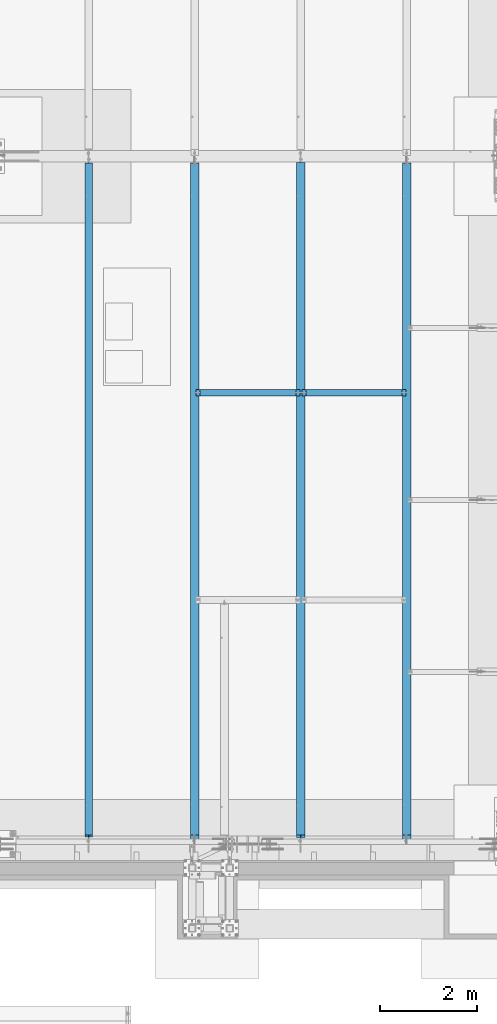
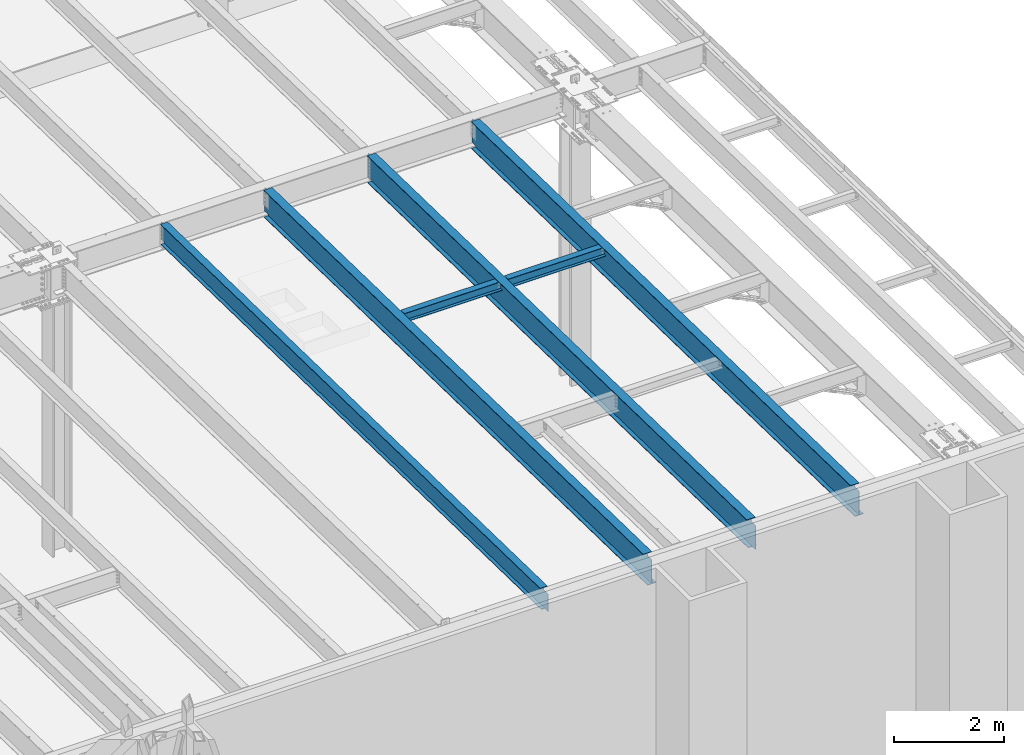
# One storey, part 1112 of 1763: 6 beams, 6 elements without a shape of their own.
"""IFC2X3 building model written with IfcOpenShell, lengths in millimetres."""

from ifc_helpers import new_model, si_unit, frame, origin_with_axes, place, context, subcontext, project, spatial, faceted_brep, material, type_object, element, aggregate, save


model = new_model("IFC2X3")

# Units and contexts
model_context = context("Model", 3, precision=1e-05, world=origin_with_axes())
body_context = subcontext(model_context, "Body", "Model", "MODEL_VIEW")
ifc_project = project(units=[si_unit("LENGTHUNIT", "METRE", prefix="MILLI"), si_unit("AREAUNIT", "SQUARE_METRE"), si_unit("VOLUMEUNIT", "CUBIC_METRE"), si_unit("MASSUNIT", "GRAM", prefix="KILO"), si_unit("TIMEUNIT", "SECOND"), si_unit("PLANEANGLEUNIT", "RADIAN"), si_unit("SOLIDANGLEUNIT", "STERADIAN"), si_unit("THERMODYNAMICTEMPERATUREUNIT", "DEGREE_CELSIUS"), si_unit("LUMINOUSINTENSITYUNIT", "LUMEN")], contexts=[model_context])

# Site, building, storey
site_placement = place(None, origin_with_axes())
site = spatial("IfcSite", under=ifc_project, at=site_placement, CompositionType="ELEMENT")
building_placement = place(site_placement, origin_with_axes())
building = spatial("IfcBuilding", under=site, at=building_placement, Name="Undefined", CompositionType="ELEMENT")
storey_placement = place(building_placement, origin_with_axes())
storey = spatial("IfcBuildingStorey", under=building, at=storey_placement, Name="Undefined", CompositionType="ELEMENT", Elevation=0.0)

# Assembly, beam
assembly_1_placement = place(storey_placement, origin_with_axes())
assembly_1 = element("IfcElementAssembly", 1, at=assembly_1_placement, inside=storey, Name="BEAM", AssemblyPlace="NOTDEFINED", PredefinedType="RIGID_FRAME")
ifc_material = material(Name="STEEL/A992")
beam_type_1 = type_object("IfcBeamType", Name="W8X18", PredefinedType="NOTDEFINED")
beam_1_placement = place(assembly_1_placement, frame((-30581.0372736983, -4419.6, 11907.1626782421), z_axis=(0.0, 0.0, 1.0), x_axis=(1.0, 0.0, 0.0)))
beam_1 = element("IfcBeam", 2, at=beam_1_placement, type_object=beam_type_1, material=ifc_material, Name="BEAM", ObjectType="W8X18", context=body_context, shape_type="Brep", body=[
    faceted_brep([(87.3125001907247, -3.17500000000018, 64.8275016680727), (87.3125001907247, 3.17500000000018, 64.8275016680727), (17.4624999999905, 3.17500000000018, 64.8275016680727), (17.4624999999905, -3.17500000000018, 64.8275016680727), (92.1725797087711, -3.17500000000018, 65.7942315906603), (92.1725797087711, 3.17500000000018, 65.7942315906603), (96.2927561769247, -3.17500000000018, 68.5472454911378), (96.2927561769247, 3.17500000000018, 68.5472454911378), (97.1527139098253, -3.17500000000018, 69.8342631898486), (97.1527139098253, 3.17500000000018, 69.8342631898486), (17.4624999999905, -3.17500000000018, -95.25), (17.4624999999905, -66.6750000000002, -95.25), (2166.93749999999, -66.6750000000002, -95.25), (2166.93749999999, -3.17500000000018, -95.25), (17.4624999999905, -66.6750000000002, -103.1875), (2166.93749999999, -66.6750000000002, -103.1875), (17.4624999999905, 66.6750000000002, -103.1875), (2166.93749999999, 66.6750000000002, -103.1875), (17.4624999999905, 66.6750000000002, -95.25), (2166.93749999999, 66.6750000000002, -95.25), (17.4624999999905, 3.17500000000018, -95.25), (2166.93749999999, 3.17500000000018, -95.25), (2166.93749999999, 3.17500000000018, 64.8275016741882), (2166.93749999999, -3.17500000000018, 64.8275016741882), (2097.08749980926, 3.17500000000018, 64.8275016741882), (2097.08749980926, -3.17500000000018, 64.8275016741882), (2092.22742029121, 3.17500000000018, 65.7942315967757), (2092.22742029121, -3.17500000000018, 65.7942315967757), (2088.10724382306, 3.17500000000018, 68.5472454972532), (2088.10724382306, -3.17500000000018, 68.5472454972532), (2087.2472860971, 3.17500000000018, 69.8342631855776), (2087.2472860971, -3.17500000000018, 69.8342631855776), (2086.51974687482, 3.17500000000018, 70.3203893521513), (2086.51974687482, -3.17500000000018, 70.3203893521513), (2083.76673297434, 3.17500000000018, 74.440565820305), (2083.76673297434, -3.17500000000018, 74.440565820305), (2082.80000305175, 3.17500000000018, 79.3006453383514), (2082.80000305175, -3.17500000000018, 79.3006453383514), (2082.80000305175, -66.6750000000002, 103.1875), (2082.80000305175, -66.6750000000002, 95.25), (2082.80000305175, -3.17500000000018, 95.25), (2082.80000305175, 3.17500000000018, 95.25), (2082.80000305175, 66.6750000000002, 95.25), (2082.80000305175, 66.6750000000002, 103.1875), (101.599996948244, 3.17500000000018, 95.25), (101.599996948244, 66.6750000000002, 95.25), (101.599996948244, 66.6750000000002, 103.1875), (101.599996948244, -66.6750000000002, 103.1875), (101.599996948244, -66.6750000000002, 95.25), (101.599996948244, -3.17500000000018, 95.25), (101.599996948244, 3.17500000000018, 79.3006453379949), (101.599996948244, -3.17500000000018, 79.3006453379949), (100.633267025656, 3.17500000000018, 74.4405658199485), (100.633267025656, -3.17500000000018, 74.4405658199485), (97.8802531251786, 3.17500000000018, 70.3203893517948), (97.8802531251786, -3.17500000000018, 70.3203893517948)], [[[0, 1, 2, 3]], [[4, 5, 1, 0]], [[6, 7, 5, 4]], [[8, 9, 7, 6]], [[10, 11, 12, 13]], [[11, 14, 15, 12]], [[14, 16, 17, 15]], [[16, 18, 19, 17]], [[18, 20, 21, 19]], [[13, 12, 15, 17, 19, 21, 22, 23]], [[23, 22, 24, 25]], [[25, 24, 26, 27]], [[27, 26, 28, 29]], [[29, 28, 30, 31]], [[32, 33, 31, 30]], [[33, 32, 34, 35]], [[35, 34, 36, 37]], [[38, 39, 40, 37, 36, 41, 42, 43]], [[42, 41, 44, 45]], [[43, 42, 45, 46]], [[38, 43, 46, 47]], [[39, 38, 47, 48]], [[40, 39, 48, 49]], [[47, 46, 45, 44, 50, 51, 49, 48]], [[51, 50, 52, 53]], [[53, 52, 54, 55]], [[4, 0, 3, 10, 13, 23, 25, 27, 29, 31, 33, 35, 37, 40, 49, 51, 53, 55, 8, 6]], [[20, 18, 16, 14, 11, 10, 3, 2]], [[54, 52, 50, 44, 41, 36, 34, 32, 30, 28, 26, 24, 22, 21, 20, 2, 1, 5, 7, 9]], [[55, 54, 9, 8]]]),
])
aggregate(assembly_1, [beam_1])

assembly_2_placement = place(storey_placement, origin_with_axes())
assembly_2 = element("IfcElementAssembly", 3, at=assembly_2_placement, inside=storey, Name="BEAM", AssemblyPlace="NOTDEFINED", PredefinedType="RIGID_FRAME")
beam_2_placement = place(assembly_2_placement, frame((-28396.6372736983, -4419.6, 11907.1626782421), z_axis=(0.0, 0.0, 1.0), x_axis=(1.0, 0.0, 0.0)))
beam_2 = element("IfcBeam", 4, at=beam_2_placement, type_object=beam_type_1, material=ifc_material, Name="BEAM", ObjectType="W8X18", context=body_context, shape_type="Brep", body=[
    faceted_brep([(87.3125001907247, -3.17500000000018, 64.8275016680727), (87.3125001907247, 3.17500000000018, 64.8275016680727), (17.4624999999905, 3.17500000000018, 64.8275016680727), (17.4624999999905, -3.17500000000018, 64.8275016680727), (92.1725797087711, -3.17500000000018, 65.7942315906603), (92.1725797087711, 3.17500000000018, 65.7942315906603), (96.2927561769247, -3.17500000000018, 68.5472454911378), (96.2927561769247, 3.17500000000018, 68.5472454911378), (97.1527139098253, -3.17500000000018, 69.8342631898486), (97.1527139098253, 3.17500000000018, 69.8342631898486), (17.4624999999905, -3.17500000000018, -95.25), (17.4624999999905, -66.6750000000002, -95.25), (2166.93749999999, -66.6750000000002, -95.25), (2166.93749999999, -3.17500000000018, -95.25), (17.4624999999905, -66.6750000000002, -103.1875), (2166.93749999999, -66.6750000000002, -103.1875), (17.4624999999905, 66.6750000000002, -103.1875), (2166.93749999999, 66.6750000000002, -103.1875), (17.4624999999905, 66.6750000000002, -95.25), (2166.93749999999, 66.6750000000002, -95.25), (17.4624999999905, 3.17500000000018, -95.25), (2166.93749999999, 3.17500000000018, -95.25), (2166.93749999999, 3.17500000000018, 64.8275016741882), (2166.93749999999, -3.17500000000018, 64.8275016741882), (2097.08749980926, 3.17500000000018, 64.8275016741882), (2097.08749980926, -3.17500000000018, 64.8275016741882), (2092.22742029121, 3.17500000000018, 65.7942315967757), (2092.22742029121, -3.17500000000018, 65.7942315967757), (2088.10724382306, 3.17500000000018, 68.5472454972532), (2088.10724382306, -3.17500000000018, 68.5472454972532), (2087.2472860971, 3.17500000000018, 69.8342631855776), (2087.2472860971, -3.17500000000018, 69.8342631855776), (2086.51974687482, 3.17500000000018, 70.3203893521513), (2086.51974687482, -3.17500000000018, 70.3203893521513), (2083.76673297434, 3.17500000000018, 74.440565820305), (2083.76673297434, -3.17500000000018, 74.440565820305), (2082.80000305175, 3.17500000000018, 79.3006453383514), (2082.80000305175, -3.17500000000018, 79.3006453383514), (2082.80000305175, 66.6750000000002, 95.25), (2082.80000305175, 3.17500000000018, 95.25), (101.599996948244, 3.17500000000018, 95.25), (101.599996948244, 66.6750000000002, 95.25), (2082.80000305175, -66.6750000000002, 95.25), (2082.80000305175, -66.6750000000002, 103.1875), (101.599996948244, -66.6750000000002, 103.1875), (101.599996948244, -66.6750000000002, 95.25), (2082.80000305175, 66.6750000000002, 103.1875), (101.599996948244, 66.6750000000002, 103.1875), (2082.80000305175, -3.17500000000018, 95.25), (101.599996948244, -3.17500000000018, 95.25), (101.599996948244, 3.17500000000018, 79.3006453379949), (101.599996948244, -3.17500000000018, 79.3006453379949), (100.633267025656, 3.17500000000018, 74.4405658199485), (100.633267025656, -3.17500000000018, 74.4405658199485), (97.8802531251786, 3.17500000000018, 70.3203893517948), (97.8802531251786, -3.17500000000018, 70.3203893517948)], [[[0, 1, 2, 3]], [[4, 5, 1, 0]], [[6, 7, 5, 4]], [[8, 9, 7, 6]], [[10, 11, 12, 13]], [[11, 14, 15, 12]], [[14, 16, 17, 15]], [[16, 18, 19, 17]], [[18, 20, 21, 19]], [[13, 12, 15, 17, 19, 21, 22, 23]], [[23, 22, 24, 25]], [[25, 24, 26, 27]], [[27, 26, 28, 29]], [[29, 28, 30, 31]], [[32, 33, 31, 30]], [[33, 32, 34, 35]], [[35, 34, 36, 37]], [[38, 39, 40, 41]], [[42, 43, 44, 45]], [[43, 46, 47, 44]], [[46, 38, 41, 47]], [[43, 42, 48, 37, 36, 39, 38, 46]], [[48, 42, 45, 49]], [[44, 47, 41, 40, 50, 51, 49, 45]], [[51, 50, 52, 53]], [[53, 52, 54, 55]], [[4, 0, 3, 10, 13, 23, 25, 27, 29, 31, 33, 35, 37, 48, 49, 51, 53, 55, 8, 6]], [[20, 18, 16, 14, 11, 10, 3, 2]], [[54, 52, 50, 40, 39, 36, 34, 32, 30, 28, 26, 24, 22, 21, 20, 2, 1, 5, 7, 9]], [[55, 54, 9, 8]]]),
])
aggregate(assembly_2, [beam_2])

assembly_3_placement = place(storey_placement, origin_with_axes())
assembly_3 = element("IfcElementAssembly", 5, at=assembly_3_placement, inside=storey, Name="BEAM", AssemblyPlace="NOTDEFINED", PredefinedType="RIGID_FRAME")
beam_type_2 = type_object("IfcBeamType", Name="W18X35", PredefinedType="NOTDEFINED")
beam_3_placement = place(assembly_3_placement, frame((-32765.4372736983, -13720.7116289294, 11979.324245716), z_axis=(0.0, 0.0209013539966291, 0.999781542838788), x_axis=(0.0, 0.999781542776098, -0.0209013569953182)))
beam_3 = element("IfcBeam", 6, at=beam_3_placement, type_object=beam_type_2, material=ifc_material, Name="BEAM", ObjectType="W18X35", context=body_context, shape_type="Brep", body=[
    faceted_brep([(46.5076420986352, -3.96875, -214.312500000187), (46.7399591684753, -3.96799993515015, -225.425000000196), (151.611759830872, -3.96867178774846, -225.42500000023), (151.611759830901, -3.96875, -214.312500000222), (151.611769293175, -76.2000000000007, -214.31250000022), (151.611769293171, -76.2000000000007, -225.42500000023), (183.36174875174, 3.96875, 214.312500000113), (183.36174875174, 76.1999999999971, 214.312500000113), (14040.4620514094, 76.1999999999971, 214.312499995547), (14040.4620514094, 3.96875, 214.312499995547), (151.611749405523, 76.1999999999971, -225.42500000023), (151.611749405525, 76.1999999999971, -214.31250000022), (14040.4620514095, 76.1999999999971, -214.312500004797), (14040.4620514095, 76.1999999999971, -225.425000004807), (46.5076420986352, 3.96950006484985, -214.312500000187), (46.7399591684753, 3.96950006484985, -225.425000000196), (34.0371841557462, 3.96950006484985, -225.425000000192), (33.8048670859043, 3.96875, -214.312500000182), (151.611758867988, 3.96867184207076, -214.312500012245), (151.611758867959, 3.96883425640408, -225.425000000228), (14040.4620514095, 3.96874929308251, -214.312500004906), (14048.3019717007, -3.96875, -194.641730046387), (14048.3019717007, 3.96877083477739, -194.641730046387), (14053.1620512188, 3.96877091782517, -193.675000123798), (14053.1620512188, -3.96875, -193.675000123798), (14044.1817952326, -3.96875, -197.394743946868), (14044.1817952326, 3.96877060156112, -197.394743946868), (14041.4287813321, -3.96875, -201.514920415033), (14041.4287813321, 3.96877025369031, -201.514920415033), (14040.4620514095, -3.96875, -206.374999933088), (14040.4620514095, 3.96876984411938, -206.374999933088), (14040.4620514095, -3.96875, -214.312500004797), (14040.4620514095, -76.2000000000007, -214.312500004797), (14040.4620514095, -76.2000000000007, -225.425000004807), (34.0371841557462, -3.96799993515015, -225.425000000192), (33.8048670859043, -3.96875, -214.312500000182), (33.6561982054209, -3.96875, -207.201171781697), (25.9392748641658, -3.96875, 161.925000000279), (25.9392748641658, 3.96875, 161.925000000279), (33.656195778487, 3.96875, -207.201055693391), (38.6420498768948, -3.96875, 161.925000000274), (170.66174894243, -3.96875, 161.925000000232), (170.66174894243, 3.96872804714076, 161.925000000232), (175.521828460485, -3.96875, 162.89172992282), (175.521828460485, 3.96872720104875, 162.89172992282), (179.64200492865, -3.96875, 165.644743823304), (179.64200492865, 3.96872478980367, 165.644743823304), (182.395018829136, -3.96875, 169.764920291467), (182.395018829136, 3.96872118050669, 169.764920291467), (183.361748751728, -3.96875, 174.624999809523), (183.361748751728, 3.96871692263085, 174.624999809523), (183.361748751746, -76.2000000000007, 225.425000000123), (183.361748751746, 76.1999999999971, 225.425000000123), (183.36174875174, -3.96875, 214.312500000113), (183.36174875174, -76.2000000000007, 214.312500000113), (14040.4620514094, -3.96875, 214.312499995547), (14040.4620514094, -76.2000000000007, 214.312499995547), (14040.4620514094, -76.2000000000007, 225.424999995557), (14040.4620514094, 76.1999999999971, 225.424999995557), (14040.4620514095, -3.96875, 200.024999686655), (14040.4620514095, 3.96880300722842, 200.024999686655), (14041.428781332, -3.96875, 195.164920168596), (14041.428781332, 3.96880259882892, 195.164920168596), (14044.1817952325, -3.96875, 191.044743700433), (14044.1817952325, 3.96880225304631, 191.044743700433), (14048.3019717007, -3.96875, 188.29172979995), (14048.3019717007, 3.96880202252214, 188.29172979995), (14053.1620512187, -3.96875, 187.324999877359), (14053.1620512187, 3.96880194235564, 187.324999877359), (14158.8331315265, -3.96875, 187.324999877359), (14158.8331315265, 3.96875, 187.324999877359), (14166.7982882068, -3.96875, -193.675000123865), (14166.7982882068, 3.96875, -193.675000123865)], [[[0, 1, 2, 3]], [[4, 3, 2, 5]], [[6, 7, 8, 9]], [[10, 11, 12, 13]], [[14, 15, 16, 17]], [[18, 19, 15, 14]], [[11, 10, 19, 18]], [[11, 18, 20, 12]], [[21, 22, 23, 24]], [[25, 26, 22, 21]], [[27, 28, 26, 25]], [[29, 30, 28, 27]], [[31, 32, 33, 13, 12, 20, 30, 29]], [[33, 32, 4, 5]], [[1, 34, 16, 15, 19, 10, 13, 33, 5, 2]], [[35, 34, 1, 0]], [[36, 37, 38, 39, 17, 16, 34, 35]], [[40, 41, 42, 38, 37]], [[43, 44, 42, 41]], [[45, 46, 44, 43]], [[47, 48, 46, 45]], [[49, 50, 48, 47]], [[51, 52, 7, 6, 50, 49, 53, 54]], [[54, 53, 55, 56]], [[51, 54, 56, 57]], [[52, 51, 57, 58]], [[7, 52, 58, 8]], [[57, 56, 55, 59, 60, 9, 8, 58]], [[61, 62, 60, 59]], [[63, 64, 62, 61]], [[65, 66, 64, 63]], [[67, 68, 66, 65]], [[69, 70, 68, 67]], [[70, 69, 71, 72]], [[22, 26, 28, 30, 20, 18, 14, 17, 39, 38, 42, 44, 46, 48, 50, 6, 9, 60, 62, 64, 66, 68, 70, 72, 23]], [[71, 24, 23, 72]], [[69, 67, 65, 63, 61, 59, 55, 53, 49, 47, 45, 43, 41, 40, 37, 36, 35, 0, 3, 31, 29, 27, 25, 21, 24, 71]], [[32, 31, 3, 4]]]),
])
aggregate(assembly_3, [beam_3])

assembly_4_placement = place(storey_placement, origin_with_axes())
assembly_4 = element("IfcElementAssembly", 7, at=assembly_4_placement, inside=storey, Name="BEAM", AssemblyPlace="NOTDEFINED", PredefinedType="RIGID_FRAME")
beam_type_3 = type_object("IfcBeamType", Name="W24X55", PredefinedType="NOTDEFINED")
beam_4_placement = place(assembly_4_placement, frame((-26212.2372736983, -13722.2711313756, 11904.7280453544), z_axis=(0.0, 0.0209013539966291, 0.999781542838788), x_axis=(0.0, 0.999781542776098, -0.0209013569953182)))
beam_4 = element("IfcBeam", 8, at=beam_4_placement, type_object=beam_type_3, material=ifc_material, Name="BEAM", ObjectType="W24X55", context=body_context, shape_type="Brep", body=[
    faceted_brep([(14037.30917679, -4.76250000000073, -287.337500004858), (14037.30917679, -88.9000000000015, -287.337500004858), (14037.30917679, -88.9000000000015, -300.037500004868), (14037.30917679, 88.9000000000015, -300.037500004868), (14037.30917679, 88.9000000000015, -287.337500004858), (14037.30917679, 4.76250000000073, -287.337500004858), (14037.30917679, 4.76250000000073, -274.897499985593), (14037.30917679, -4.76250000000073, -274.897499985593), (14038.2759067126, 4.76250000000073, -270.037420467535), (14038.2759067126, -4.76250000000073, -270.037420467535), (14041.0289206131, 4.76250000000073, -265.917243999373), (14041.0289206131, -4.76250000000073, -265.917243999373), (14045.1490970812, 4.76250000000073, -263.164230098891), (14045.1490970812, -4.76250000000073, -263.164230098891), (14050.0091765993, 4.76250000000073, -262.197500176302), (14050.0091765993, -4.76250000000073, -262.197500176302), (14169.790657525, -4.76250000000073, -262.197500176375), (14169.790657525, 4.76250000000073, -262.197500176375), (183.284309659486, 4.76250000000073, 287.337500000171), (183.284309659486, 88.9000000000015, 287.337500000171), (14037.30917679, 88.9000000000015, 287.337499995603), (14037.30917679, 4.76250000000073, 287.337499995603), (36.8913653215495, 4.76250000000073, -287.337500000245), (36.8913653215495, 88.9000000000015, -287.337500000245), (37.1568705442241, 88.9000000000015, -300.037500000257), (37.1568705442241, -88.9000000000015, -300.037500000257), (36.8913653215495, -88.9000000000015, -287.337500000245), (36.8913653215495, -4.76250000000073, -287.337500000245), (25.9447104708634, -4.76250000000073, 236.277497864299), (25.9447104708634, 4.76250000000073, 236.277497864299), (170.584309850175, -4.76250000000073, 236.27749786425), (170.584309850175, 4.76250000000073, 236.27749786425), (175.444389368233, -4.76250000000073, 237.244227786839), (175.444389368233, 4.76250000000073, 237.244227786839), (179.564565836397, -4.76250000000073, 239.997241687322), (179.564565836397, 4.76250000000073, 239.997241687322), (182.317579736884, -4.76250000000073, 244.117418155483), (182.317579736884, 4.76250000000073, 244.117418155483), (183.284309659475, -4.76250000000073, 248.977497673543), (183.284309659475, 4.76250000000073, 248.977497673543), (183.28430965949, -88.9000000000015, 300.037500000179), (183.28430965949, 88.9000000000015, 300.037500000179), (183.284309659486, -4.76250000000073, 287.337500000171), (183.284309659486, -88.9000000000015, 287.337500000171), (14037.30917679, -4.76250000000073, 287.337499995603), (14037.30917679, -88.9000000000015, 287.337499995603), (14037.30917679, -88.9000000000015, 300.037499995613), (14037.30917679, 88.9000000000015, 300.037499995613), (14037.30917679, -4.76250000000073, 274.37750131296), (14037.30917679, 4.76250000000073, 274.37750131296), (14038.2759067126, -4.76250000000073, 269.517421794906), (14038.2759067126, 4.76250000000073, 269.517421794906), (14041.028920613, -4.76250000000073, 265.397245326743), (14041.028920613, 4.76250000000073, 265.397245326743), (14045.1490970812, -4.76250000000073, 262.644231426257), (14045.1490970812, 4.76250000000073, 262.644231426257), (14050.0091765993, -4.76250000000073, 261.677501503666), (14050.0091765993, 4.76250000000073, 261.677501503666), (14158.8385670546, -4.76250000000073, 261.677501503667), (14158.8385670546, 4.76250000000073, 261.677501503667)], [[[0, 1, 2, 3, 4, 5, 6, 7]], [[7, 6, 8, 9]], [[9, 8, 10, 11]], [[11, 10, 12, 13]], [[13, 12, 14, 15]], [[16, 15, 14, 17]], [[18, 19, 20, 21]], [[22, 23, 24, 25, 26, 27, 28, 29]], [[30, 31, 29, 28]], [[32, 33, 31, 30]], [[34, 35, 33, 32]], [[36, 37, 35, 34]], [[38, 39, 37, 36]], [[40, 41, 19, 18, 39, 38, 42, 43]], [[43, 42, 44, 45]], [[40, 43, 45, 46]], [[41, 40, 46, 47]], [[19, 41, 47, 20]], [[46, 45, 44, 48, 49, 21, 20, 47]], [[50, 51, 49, 48]], [[52, 53, 51, 50]], [[54, 55, 53, 52]], [[56, 57, 55, 54]], [[58, 59, 57, 56]], [[59, 58, 16, 17]], [[12, 10, 8, 6, 5, 22, 29, 31, 33, 35, 37, 39, 18, 21, 49, 51, 53, 55, 57, 59, 17, 14]], [[23, 22, 5, 4]], [[24, 23, 4, 3]], [[25, 24, 3, 2]], [[26, 25, 2, 1]], [[27, 26, 1, 0]], [[58, 56, 54, 52, 50, 48, 44, 42, 38, 36, 34, 32, 30, 28, 27, 0, 7, 9, 11, 13, 15, 16]]]),
])
aggregate(assembly_4, [beam_4])

assembly_5_placement = place(storey_placement, origin_with_axes())
assembly_5 = element("IfcElementAssembly", 9, at=assembly_5_placement, inside=storey, Name="BEAM", AssemblyPlace="NOTDEFINED", PredefinedType="RIGID_FRAME")
beam_5_placement = place(assembly_5_placement, frame((-28396.6372736983, -13722.2711313756, 11904.7280453544), z_axis=(0.0, 0.0209013539966291, 0.999781542838788), x_axis=(0.0, 0.999781542776098, -0.0209013569953182)))
beam_5 = element("IfcBeam", 10, at=beam_5_placement, type_object=beam_type_3, material=ifc_material, Name="BEAM", ObjectType="W24X55", context=body_context, shape_type="Brep", body=[
    faceted_brep([(36.8913653215495, -4.76250000000073, -287.337500000245), (37.1568705442241, -4.7623931827402, -300.037500000257), (151.611761608232, -4.76237818914524, -300.037500000293), (151.611761608265, -4.76250000000073, -287.337500000282), (151.611772630264, -88.9000000000015, -287.337500000282), (151.611772630258, -88.9000000000015, -300.037500000291), (183.361748773876, 4.76250000000073, 287.337500000169), (183.361748773876, 88.9000000000015, 287.337500000169), (14043.5817378554, 88.9000000000015, 287.337499995601), (14043.5817378554, 4.76250000000073, 287.337499995601), (14043.5817378554, 88.9000000000015, -287.33750000486), (14043.5817378554, 88.9000000000015, -300.037500004872), (151.611749427093, 88.9000000000015, -300.037500000291), (151.611749427098, 88.9000000000015, -287.337500000282), (151.611760448979, 4.76237821900577, -287.337500002675), (151.611760448948, 4.76262784460778, -300.037500000293), (37.1568705442241, 4.76261285108558, -300.037500000257), (36.8913653215495, 4.76250000000073, -287.337500000245), (14043.5817378554, 4.76250000000073, -287.33750000486), (14051.4216581466, -4.76250000000073, -275.604230098941), (14051.4216581466, 4.76250000000073, -275.604230098941), (14056.2817376647, 4.76250000000073, -274.637500176354), (14056.2817376647, -4.76250000000073, -274.637500176354), (14047.3014816785, -4.76250000000073, -278.357243999422), (14047.3014816785, 4.76250000000073, -278.357243999422), (14044.548467778, -4.76250000000073, -282.477420467587), (14044.548467778, 4.76250000000073, -282.477420467587), (14043.5817378554, -4.76250000000073, -287.33750000486), (14043.5817378554, -88.9000000000015, -287.33750000486), (14043.5817378554, -88.9000000000015, -300.037500004872), (36.7095222771895, -4.76250000000073, -278.639340920341), (25.9392748862119, -4.76250000000073, 236.537500000519), (25.9392748862119, 4.76250000000073, 236.537500000519), (36.7095183647198, 4.76250000000073, -278.639153773845), (170.661748964563, -4.76250000000073, 236.53750000047), (170.661748964563, 4.76250000000073, 236.53750000047), (175.521828482621, -4.76250000000073, 237.504229923057), (175.521828482621, 4.76250000000073, 237.504229923057), (179.642004950787, -4.76250000000073, 240.257243823542), (179.642004950787, 4.76250000000073, 240.257243823542), (182.395018851272, -4.76250000000073, 244.377420291703), (182.395018851272, 4.76250000000073, 244.377420291703), (183.361748773863, -4.76250000000073, 249.237499809762), (183.361748773863, 4.76250000000073, 249.237499809762), (183.361748773879, -88.9000000000015, 300.03750000018), (183.361748773879, 88.9000000000015, 300.03750000018), (183.361748773876, -4.76250000000073, 287.337500000169), (183.361748773876, -88.9000000000015, 287.337500000169), (14043.5817378554, -4.76250000000073, 287.337499995601), (14043.5817378554, -88.9000000000015, 287.337499995601), (14043.5817378554, -88.9000000000015, 300.037499995613), (14043.5817378554, 88.9000000000015, 300.037499995613), (14043.5817378554, -4.76250000000073, 274.637499634478), (14043.5817378554, 4.76250000000073, 274.637499634478), (14044.548467778, -4.76250000000073, 269.777420116421), (14044.548467778, 4.76250000000073, 269.777420116421), (14047.3014816785, -4.76250000000073, 265.65724364826), (14047.3014816785, 4.76250000000073, 265.65724364826), (14051.4216581466, -4.76250000000073, 262.904229747772), (14051.4216581466, 4.76250000000073, 262.904229747772), (14056.2817376647, -4.76250000000073, 261.937499825182), (14056.2817376647, 4.76250000000073, 261.937499825182), (14158.8331315497, -4.76250000000073, 261.937499825184), (14158.8331315497, 4.76250000000073, 261.937499825184), (14170.0507272077, -4.76250000000073, -274.637500176425), (14170.0507272077, 4.76250000000073, -274.637500176425)], [[[0, 1, 2, 3]], [[4, 3, 2, 5]], [[6, 7, 8, 9]], [[10, 11, 12, 13]], [[14, 15, 16, 17]], [[13, 12, 15, 14]], [[18, 10, 13, 14]], [[19, 20, 21, 22]], [[23, 24, 20, 19]], [[25, 26, 24, 23]], [[27, 18, 26, 25]], [[28, 29, 11, 10, 18, 27]], [[29, 28, 4, 5]], [[1, 16, 15, 12, 11, 29, 5, 2]], [[30, 31, 32, 33, 17, 16, 1, 0]], [[34, 35, 32, 31]], [[36, 37, 35, 34]], [[38, 39, 37, 36]], [[40, 41, 39, 38]], [[42, 43, 41, 40]], [[44, 45, 7, 6, 43, 42, 46, 47]], [[47, 46, 48, 49]], [[44, 47, 49, 50]], [[45, 44, 50, 51]], [[7, 45, 51, 8]], [[50, 49, 48, 52, 53, 9, 8, 51]], [[54, 55, 53, 52]], [[56, 57, 55, 54]], [[58, 59, 57, 56]], [[60, 61, 59, 58]], [[62, 63, 61, 60]], [[63, 62, 64, 65]], [[20, 24, 26, 18, 14, 17, 33, 32, 35, 37, 39, 41, 43, 6, 9, 53, 55, 57, 59, 61, 63, 65, 21]], [[64, 22, 21, 65]], [[62, 60, 58, 56, 54, 52, 48, 46, 42, 40, 38, 36, 34, 31, 30, 0, 3, 27, 25, 23, 19, 22, 64]], [[28, 27, 3, 4]]]),
])
aggregate(assembly_5, [beam_5])

assembly_6_placement = place(storey_placement, origin_with_axes())
assembly_6 = element("IfcElementAssembly", 11, at=assembly_6_placement, inside=storey, Name="BEAM", AssemblyPlace="NOTDEFINED", PredefinedType="RIGID_FRAME")
beam_6_placement = place(assembly_6_placement, frame((-30581.0372736983, -13722.2711313756, 11904.7280453544), z_axis=(0.0, 0.0209013539966291, 0.999781542838788), x_axis=(0.0, 0.999781542776098, -0.0209013569953182)))
beam_6 = element("IfcBeam", 12, at=beam_6_placement, type_object=beam_type_3, material=ifc_material, Name="BEAM", ObjectType="W24X55", context=body_context, shape_type="Brep", body=[
    faceted_brep([(14037.30917679, -4.76250000000073, -287.337500004858), (14037.30917679, -88.9000000000015, -287.337500004858), (14037.30917679, -88.9000000000015, -300.037500004868), (14037.30917679, 88.9000000000015, -300.037500004868), (14037.30917679, 88.9000000000015, -287.337500004858), (14037.30917679, 4.76250000000073, -287.337500004858), (14037.30917679, 4.76250000000073, -274.897499985593), (14037.30917679, -4.76250000000073, -274.897499985593), (14038.2759067126, 4.76250000000073, -270.037420467535), (14038.2759067126, -4.76250000000073, -270.037420467535), (14041.0289206131, 4.76250000000073, -265.917243999373), (14041.0289206131, -4.76250000000073, -265.917243999373), (14045.1490970812, 4.76250000000073, -263.164230098891), (14045.1490970812, -4.76250000000073, -263.164230098891), (14050.0091765993, 4.76250000000073, -262.197500176302), (14050.0091765993, -4.76250000000073, -262.197500176302), (14169.790657525, -4.76250000000073, -262.197500176375), (14169.790657525, 4.76250000000073, -262.197500176375), (183.284309659486, 4.76250000000073, 287.337500000171), (183.284309659486, 88.9000000000015, 287.337500000171), (14037.30917679, 88.9000000000015, 287.337499995603), (14037.30917679, 4.76250000000073, 287.337499995603), (36.8913653215495, 4.76250000000073, -287.337500000245), (36.8913653215495, 88.9000000000015, -287.337500000245), (37.1568705442241, 88.9000000000015, -300.037500000257), (37.1568705442241, -88.9000000000015, -300.037500000257), (36.8913653215495, -88.9000000000015, -287.337500000245), (36.8913653215495, -4.76250000000073, -287.337500000245), (25.9447104708634, -4.76250000000073, 236.277497864299), (25.9447104708634, 4.76250000000073, 236.277497864299), (170.584309850175, -4.76250000000073, 236.27749786425), (170.584309850175, 4.76250000000073, 236.27749786425), (175.444389368233, -4.76250000000073, 237.244227786839), (175.444389368233, 4.76250000000073, 237.244227786839), (179.564565836397, -4.76250000000073, 239.997241687322), (179.564565836397, 4.76250000000073, 239.997241687322), (182.317579736884, -4.76250000000073, 244.117418155483), (182.317579736884, 4.76250000000073, 244.117418155483), (183.284309659475, -4.76250000000073, 248.977497673543), (183.284309659475, 4.76250000000073, 248.977497673543), (183.28430965949, -88.9000000000015, 300.037500000179), (183.28430965949, 88.9000000000015, 300.037500000179), (183.284309659486, -4.76250000000073, 287.337500000171), (183.284309659486, -88.9000000000015, 287.337500000171), (14037.30917679, -4.76250000000073, 287.337499995603), (14037.30917679, -88.9000000000015, 287.337499995603), (14037.30917679, -88.9000000000015, 300.037499995613), (14037.30917679, 88.9000000000015, 300.037499995613), (14037.30917679, -4.76250000000073, 274.37750131296), (14037.30917679, 4.76250000000073, 274.37750131296), (14038.2759067126, -4.76250000000073, 269.517421794906), (14038.2759067126, 4.76250000000073, 269.517421794906), (14041.028920613, -4.76250000000073, 265.397245326743), (14041.028920613, 4.76250000000073, 265.397245326743), (14045.1490970812, -4.76250000000073, 262.644231426257), (14045.1490970812, 4.76250000000073, 262.644231426257), (14050.0091765993, -4.76250000000073, 261.677501503666), (14050.0091765993, 4.76250000000073, 261.677501503666), (14158.8385670546, -4.76250000000073, 261.677501503667), (14158.8385670546, 4.76250000000073, 261.677501503667)], [[[0, 1, 2, 3, 4, 5, 6, 7]], [[7, 6, 8, 9]], [[9, 8, 10, 11]], [[11, 10, 12, 13]], [[13, 12, 14, 15]], [[16, 15, 14, 17]], [[18, 19, 20, 21]], [[22, 23, 24, 25, 26, 27, 28, 29]], [[30, 31, 29, 28]], [[32, 33, 31, 30]], [[34, 35, 33, 32]], [[36, 37, 35, 34]], [[38, 39, 37, 36]], [[40, 41, 19, 18, 39, 38, 42, 43]], [[43, 42, 44, 45]], [[40, 43, 45, 46]], [[41, 40, 46, 47]], [[19, 41, 47, 20]], [[46, 45, 44, 48, 49, 21, 20, 47]], [[50, 51, 49, 48]], [[52, 53, 51, 50]], [[54, 55, 53, 52]], [[56, 57, 55, 54]], [[58, 59, 57, 56]], [[59, 58, 16, 17]], [[12, 10, 8, 6, 5, 22, 29, 31, 33, 35, 37, 39, 18, 21, 49, 51, 53, 55, 57, 59, 17, 14]], [[23, 22, 5, 4]], [[24, 23, 4, 3]], [[25, 24, 3, 2]], [[26, 25, 2, 1]], [[27, 26, 1, 0]], [[58, 56, 54, 52, 50, 48, 44, 42, 38, 36, 34, 32, 30, 28, 27, 0, 7, 9, 11, 13, 15, 16]]]),
])
aggregate(assembly_6, [beam_6])

save(model, "model.ifc")
